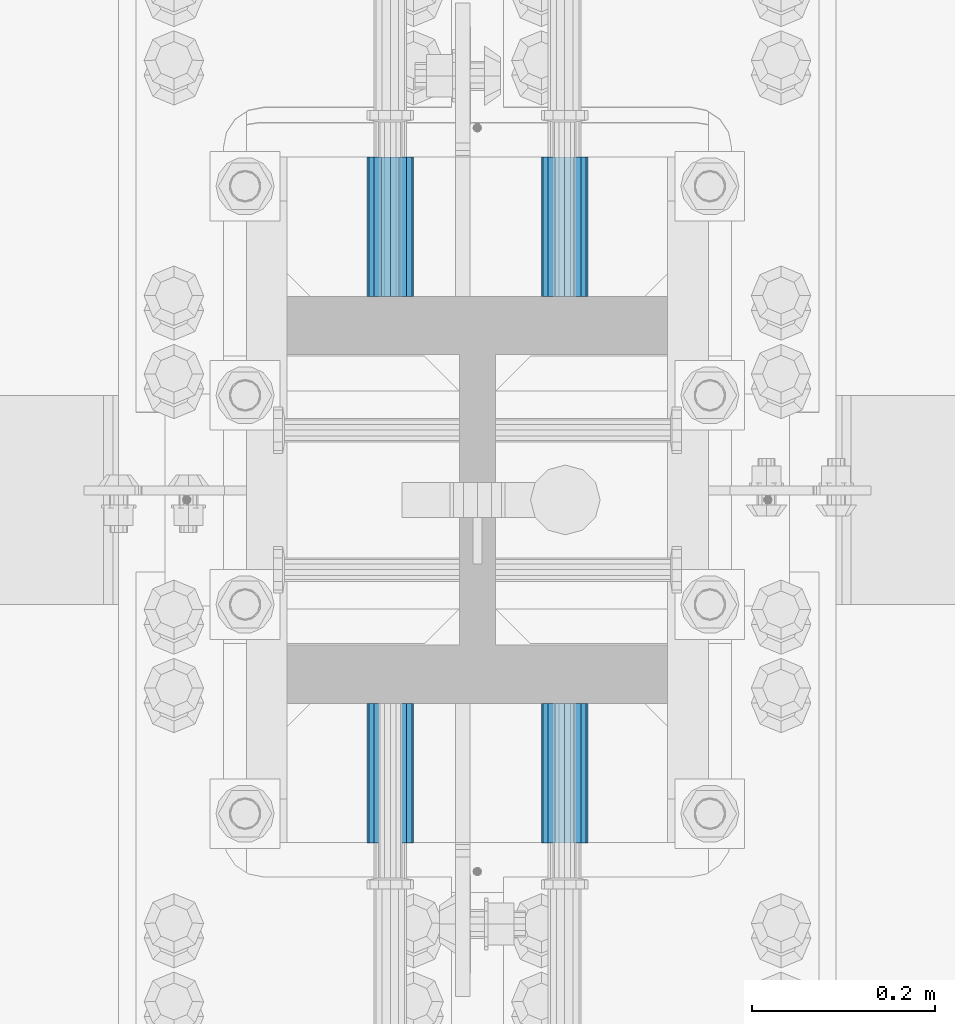
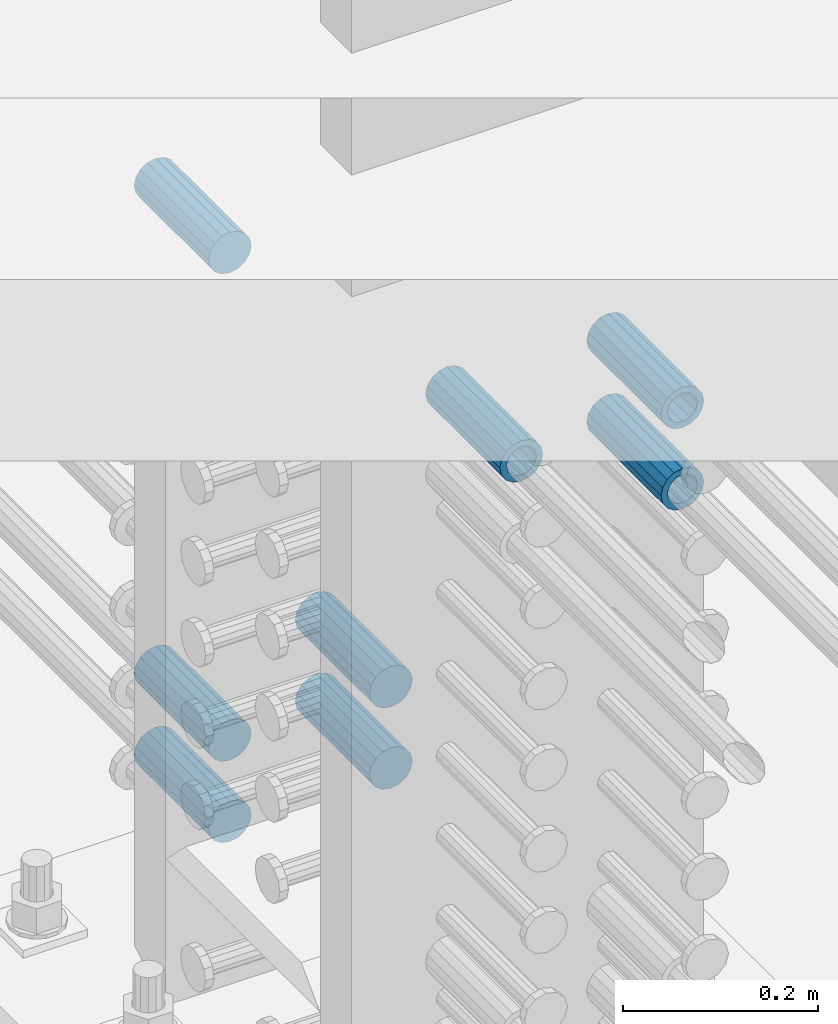
# One storey, part 1303 of 1763: 8 beams, 1 element without a shape of its own.
"""IFC2X3 building model written with IfcOpenShell, lengths in millimetres."""

from ifc_helpers import new_model, si_unit, frame, origin_with_axes, place, context, subcontext, project, spatial, faceted_brep, material, type_object, element, aggregate, save


model = new_model("IFC2X3")

# Units and contexts
model_context = context("Model", 3, precision=1e-05, world=origin_with_axes())
body_context = subcontext(model_context, "Body", "Model", "MODEL_VIEW")
ifc_project = project(units=[si_unit("LENGTHUNIT", "METRE", prefix="MILLI"), si_unit("AREAUNIT", "SQUARE_METRE"), si_unit("VOLUMEUNIT", "CUBIC_METRE"), si_unit("MASSUNIT", "GRAM", prefix="KILO"), si_unit("TIMEUNIT", "SECOND"), si_unit("PLANEANGLEUNIT", "RADIAN"), si_unit("SOLIDANGLEUNIT", "STERADIAN"), si_unit("THERMODYNAMICTEMPERATUREUNIT", "DEGREE_CELSIUS"), si_unit("LUMINOUSINTENSITYUNIT", "LUMEN")], contexts=[model_context])

# Site, building, storey
site_placement = place(None, origin_with_axes())
site = spatial("IfcSite", under=ifc_project, at=site_placement, CompositionType="ELEMENT")
building_placement = place(site_placement, origin_with_axes())
building = spatial("IfcBuilding", under=site, at=building_placement, Name="Undefined", CompositionType="ELEMENT")
storey_placement = place(building_placement, origin_with_axes())
storey = spatial("IfcBuildingStorey", under=building, at=storey_placement, Name="Undefined", CompositionType="ELEMENT", Elevation=0.0)

# Assembly, beams
assembly_placement = place(storey_placement, origin_with_axes())
assembly = element("IfcElementAssembly", 1, at=assembly_placement, inside=storey, Name="COLUMN", AssemblyPlace="NOTDEFINED", PredefinedType="RIGID_FRAME")
ifc_material = material(Name="STEEL/A706-GR.80")
beam_type = type_object("IfcBeamType", PredefinedType="NOTDEFINED")
beam_1_placement = place(assembly_placement, frame((-23932.5872736985, 234.764284790534, 4775.20000000009), z_axis=(0.0, 0.0, 1.0), x_axis=(0.0, -1.0, 0.0)))
beam_1 = element("IfcBeam", 2, at=beam_1_placement, type_object=beam_type, material=ifc_material, Name="HALF COUPLER F", context=body_context, shape_type="Brep", body=[
    faceted_brep([(32.7659999999996, -8.95349999999962, -15.507916905568), (32.7659999999996, 0.0, -17.9070000000002), (32.7659999999996, 8.95349999999962, -15.507916905568), (32.7659999999996, 15.507916905568, -8.95350000000008), (32.7659999999996, 17.9069999999992, 0.0), (32.7659999999996, 15.507916905568, 8.95350000000008), (32.7659999999996, 8.95349999999962, 15.507916905568), (32.7659999999996, 0.0, 17.9070000000002), (32.7659999999996, -8.95349999999962, 15.507916905568), (32.7659999999996, -15.507916905568, 8.95350000000008), (32.7659999999996, -17.9069999999992, 0.0), (32.7659999999996, -15.507916905568, -8.95350000000008), (152.400103102711, -15.507916905568, 8.95350000000008), (152.400103102711, -8.95349999999962, 15.507916905568), (152.400103102711, -17.9069999999992, 0.0), (152.400103102711, -15.507916905568, -8.95350000000008), (152.400103102711, -8.95349999999962, -15.507916905568), (152.400103102711, 0.0, -17.9070000000002), (152.400103102711, 8.95349999999962, -15.507916905568), (152.400103102711, 15.507916905568, -8.95350000000008), (152.400103102711, 17.9069999999992, 0.0), (152.400103102711, 15.507916905568, 8.95350000000008), (152.400103102711, 8.95349999999962, 15.507916905568), (152.400103102711, 0.0, 17.9070000000002), (0.0, -23.466540125788, 9.72015918207308), (0.0, -17.9605122421381, 17.9605122421385), (0.0, -9.72015918207398, 23.4665401257867), (0.0, 0.0, 25.4000000000001), (0.0, 9.72015918207398, 23.4665401257867), (0.0, 17.9605122421381, 17.9605122421385), (0.0, 23.466540125788, 9.72015918207308), (0.0, 25.4000000000015, 0.0), (0.0, 23.466540125788, -9.72015918207308), (0.0, 17.9605122421381, -17.9605122421385), (0.0, 9.72015918207398, -23.4665401257867), (0.0, 0.0, -25.4000000000001), (0.0, -9.72015918207398, -23.4665401257867), (0.0, -17.9605122421381, -17.9605122421385), (0.0, -23.466540125788, -9.72015918207308), (0.0, -25.4000000000015, 0.0), (152.400103102711, -25.4000000000015, 0.0), (152.400103102711, -23.466540125788, 9.72015918207308), (152.400103102711, -17.9605122421381, 17.9605122421385), (152.400103102711, -9.72015918207398, 23.4665401257867), (152.400103102711, 0.0, 25.4000000000001), (152.400103102711, 9.72015918207398, 23.4665401257867), (152.400103102711, 17.9605122421381, 17.9605122421385), (152.400103102711, 23.466540125788, 9.72015918207308), (152.400103102711, 25.4000000000015, 0.0), (152.400103102711, 23.466540125788, -9.72015918207308), (152.400103102711, 17.9605122421381, -17.9605122421385), (152.400103102711, 9.72015918207398, -23.4665401257867), (152.400103102711, 0.0, -25.4000000000001), (152.400103102711, -9.72015918207398, -23.4665401257867), (152.400103102711, -17.9605122421381, -17.9605122421385), (152.400103102711, -23.466540125788, -9.72015918207308)], [[[0, 1, 2, 3, 4, 5, 6, 7, 8, 9, 10, 11]], [[12, 9, 8, 13]], [[14, 10, 9, 12]], [[15, 11, 10, 14]], [[16, 0, 11, 15]], [[17, 1, 0, 16]], [[18, 2, 1, 17]], [[19, 3, 2, 18]], [[20, 4, 3, 19]], [[21, 5, 4, 20]], [[22, 6, 5, 21]], [[23, 7, 6, 22]], [[13, 8, 7, 23]], [[24, 25, 26, 27, 28, 29, 30, 31, 32, 33, 34, 35, 36, 37, 38, 39]], [[24, 39, 40, 41]], [[25, 24, 41, 42]], [[26, 25, 42, 43]], [[27, 26, 43, 44]], [[28, 27, 44, 45]], [[29, 28, 45, 46]], [[30, 29, 46, 47]], [[31, 30, 47, 48]], [[32, 31, 48, 49]], [[33, 32, 49, 50]], [[34, 33, 50, 51]], [[35, 34, 51, 52]], [[36, 35, 52, 53]], [[37, 36, 53, 54]], [[38, 37, 54, 55]], [[39, 38, 55, 40]], [[54, 53, 52, 51, 50, 49, 48, 47, 46, 45, 44, 43, 42, 41, 40, 55], [21, 20, 19, 18, 17, 16, 15, 14, 12, 13, 23, 22]]]),
])
beam_2_placement = place(assembly_placement, frame((-24123.0872736984, 234.764078583961, 4876.80000000009), z_axis=(0.0, 0.0, 1.0), x_axis=(0.0, -1.0, 0.0)))
beam_2 = element("IfcBeam", 3, at=beam_2_placement, type_object=beam_type, material=ifc_material, Name="HALF COUPLER F", context=body_context, shape_type="Brep", body=[
    faceted_brep([(32.7659999999996, -8.95349999999962, -15.507916905568), (32.7659999999996, 0.0, -17.9070000000002), (32.7659999999996, 8.95349999999962, -15.507916905568), (32.7659999999996, 15.507916905568, -8.95350000000008), (32.7659999999996, 17.9069999999992, 0.0), (32.7659999999996, 15.507916905568, 8.95350000000008), (32.7659999999996, 8.95349999999962, 15.507916905568), (32.7659999999996, 0.0, 17.9070000000002), (32.7659999999996, -8.95349999999962, 15.507916905568), (32.7659999999996, -15.507916905568, 8.95350000000008), (32.7659999999996, -17.9069999999992, 0.0), (32.7659999999996, -15.507916905568, -8.95350000000008), (152.400103102711, -15.507916905568, 8.95350000000008), (152.400103102711, -8.95349999999962, 15.507916905568), (152.400103102711, -17.9069999999992, 0.0), (152.400103102711, -15.507916905568, -8.95350000000008), (152.400103102711, -8.95349999999962, -15.507916905568), (152.400103102711, 0.0, -17.9070000000002), (152.400103102711, 8.95349999999962, -15.507916905568), (152.400103102711, 15.507916905568, -8.95350000000008), (152.400103102711, 17.9069999999992, 0.0), (152.400103102711, 15.507916905568, 8.95350000000008), (152.400103102711, 8.95349999999962, 15.507916905568), (152.400103102711, 0.0, 17.9070000000002), (0.0, -23.466540125788, 9.72015918207308), (0.0, -17.9605122421381, 17.9605122421385), (0.0, -9.72015918207398, 23.4665401257867), (0.0, 0.0, 25.4000000000001), (0.0, 9.72015918207398, 23.4665401257867), (0.0, 17.9605122421381, 17.9605122421385), (0.0, 23.466540125788, 9.72015918207308), (0.0, 25.4000000000015, 0.0), (0.0, 23.466540125788, -9.72015918207308), (0.0, 17.9605122421381, -17.9605122421385), (0.0, 9.72015918207398, -23.4665401257867), (0.0, 0.0, -25.4000000000001), (0.0, -9.72015918207398, -23.4665401257867), (0.0, -17.9605122421381, -17.9605122421385), (0.0, -23.466540125788, -9.72015918207308), (0.0, -25.4000000000015, 0.0), (152.400103102711, -25.4000000000015, 0.0), (152.400103102711, -23.466540125788, 9.72015918207308), (152.400103102711, -17.9605122421381, 17.9605122421385), (152.400103102711, -9.72015918207398, 23.4665401257867), (152.400103102711, 0.0, 25.4000000000001), (152.400103102711, 9.72015918207398, 23.4665401257867), (152.400103102711, 17.9605122421381, 17.9605122421385), (152.400103102711, 23.466540125788, 9.72015918207308), (152.400103102711, 25.4000000000015, 0.0), (152.400103102711, 23.466540125788, -9.72015918207308), (152.400103102711, 17.9605122421381, -17.9605122421385), (152.400103102711, 9.72015918207398, -23.4665401257867), (152.400103102711, 0.0, -25.4000000000001), (152.400103102711, -9.72015918207398, -23.4665401257867), (152.400103102711, -17.9605122421381, -17.9605122421385), (152.400103102711, -23.466540125788, -9.72015918207308)], [[[0, 1, 2, 3, 4, 5, 6, 7, 8, 9, 10, 11]], [[12, 9, 8, 13]], [[14, 10, 9, 12]], [[15, 11, 10, 14]], [[16, 0, 11, 15]], [[17, 1, 0, 16]], [[18, 2, 1, 17]], [[19, 3, 2, 18]], [[20, 4, 3, 19]], [[21, 5, 4, 20]], [[22, 6, 5, 21]], [[23, 7, 6, 22]], [[13, 8, 7, 23]], [[24, 25, 26, 27, 28, 29, 30, 31, 32, 33, 34, 35, 36, 37, 38, 39]], [[24, 39, 40, 41]], [[25, 24, 41, 42]], [[26, 25, 42, 43]], [[27, 26, 43, 44]], [[28, 27, 44, 45]], [[29, 28, 45, 46]], [[30, 29, 46, 47]], [[31, 30, 47, 48]], [[32, 31, 48, 49]], [[33, 32, 49, 50]], [[34, 33, 50, 51]], [[35, 34, 51, 52]], [[36, 35, 52, 53]], [[37, 36, 53, 54]], [[38, 37, 54, 55]], [[39, 38, 55, 40]], [[54, 53, 52, 51, 50, 49, 48, 47, 46, 45, 44, 43, 42, 41, 40, 55], [21, 20, 19, 18, 17, 16, 15, 14, 12, 13, 23, 22]]]),
])
beam_3_placement = place(assembly_placement, frame((-23932.5872736985, 234.764147319485, 4876.80000000009), z_axis=(0.0, 0.0, 1.0), x_axis=(0.0, -1.0, 0.0)))
beam_3 = element("IfcBeam", 4, at=beam_3_placement, type_object=beam_type, material=ifc_material, Name="HALF COUPLER F", context=body_context, shape_type="Brep", body=[
    faceted_brep([(32.7659999999996, -8.95349999999962, -15.507916905568), (32.7659999999996, 0.0, -17.9070000000002), (32.7659999999996, 8.95349999999962, -15.507916905568), (32.7659999999996, 15.507916905568, -8.95350000000008), (32.7659999999996, 17.9069999999992, 0.0), (32.7659999999996, 15.507916905568, 8.95350000000008), (32.7659999999996, 8.95349999999962, 15.507916905568), (32.7659999999996, 0.0, 17.9070000000002), (32.7659999999996, -8.95349999999962, 15.507916905568), (32.7659999999996, -15.507916905568, 8.95350000000008), (32.7659999999996, -17.9069999999992, 0.0), (32.7659999999996, -15.507916905568, -8.95350000000008), (152.400103102711, -15.507916905568, 8.95350000000008), (152.400103102711, -8.95349999999962, 15.507916905568), (152.400103102711, -17.9069999999992, 0.0), (152.400103102711, -15.507916905568, -8.95350000000008), (152.400103102711, -8.95349999999962, -15.507916905568), (152.400103102711, 0.0, -17.9070000000002), (152.400103102711, 8.95349999999962, -15.507916905568), (152.400103102711, 15.507916905568, -8.95350000000008), (152.400103102711, 17.9069999999992, 0.0), (152.400103102711, 15.507916905568, 8.95350000000008), (152.400103102711, 8.95349999999962, 15.507916905568), (152.400103102711, 0.0, 17.9070000000002), (0.0, -23.466540125788, 9.72015918207308), (0.0, -17.9605122421381, 17.9605122421385), (0.0, -9.72015918207398, 23.4665401257867), (0.0, 0.0, 25.4000000000001), (0.0, 9.72015918207398, 23.4665401257867), (0.0, 17.9605122421381, 17.9605122421385), (0.0, 23.466540125788, 9.72015918207308), (0.0, 25.4000000000015, 0.0), (0.0, 23.466540125788, -9.72015918207308), (0.0, 17.9605122421381, -17.9605122421385), (0.0, 9.72015918207398, -23.4665401257867), (0.0, 0.0, -25.4000000000001), (0.0, -9.72015918207398, -23.4665401257867), (0.0, -17.9605122421381, -17.9605122421385), (0.0, -23.466540125788, -9.72015918207308), (0.0, -25.4000000000015, 0.0), (152.400103102711, -25.4000000000015, 0.0), (152.400103102711, -23.466540125788, 9.72015918207308), (152.400103102711, -17.9605122421381, 17.9605122421385), (152.400103102711, -9.72015918207398, 23.4665401257867), (152.400103102711, 0.0, 25.4000000000001), (152.400103102711, 9.72015918207398, 23.4665401257867), (152.400103102711, 17.9605122421381, 17.9605122421385), (152.400103102711, 23.466540125788, 9.72015918207308), (152.400103102711, 25.4000000000015, 0.0), (152.400103102711, 23.466540125788, -9.72015918207308), (152.400103102711, 17.9605122421381, -17.9605122421385), (152.400103102711, 9.72015918207398, -23.4665401257867), (152.400103102711, 0.0, -25.4000000000001), (152.400103102711, -9.72015918207398, -23.4665401257867), (152.400103102711, -17.9605122421381, -17.9605122421385), (152.400103102711, -23.466540125788, -9.72015918207308)], [[[0, 1, 2, 3, 4, 5, 6, 7, 8, 9, 10, 11]], [[12, 9, 8, 13]], [[14, 10, 9, 12]], [[15, 11, 10, 14]], [[16, 0, 11, 15]], [[17, 1, 0, 16]], [[18, 2, 1, 17]], [[19, 3, 2, 18]], [[20, 4, 3, 19]], [[21, 5, 4, 20]], [[22, 6, 5, 21]], [[23, 7, 6, 22]], [[13, 8, 7, 23]], [[24, 25, 26, 27, 28, 29, 30, 31, 32, 33, 34, 35, 36, 37, 38, 39]], [[24, 39, 40, 41]], [[25, 24, 41, 42]], [[26, 25, 42, 43]], [[27, 26, 43, 44]], [[28, 27, 44, 45]], [[29, 28, 45, 46]], [[30, 29, 46, 47]], [[31, 30, 47, 48]], [[32, 31, 48, 49]], [[33, 32, 49, 50]], [[34, 33, 50, 51]], [[35, 34, 51, 52]], [[36, 35, 52, 53]], [[37, 36, 53, 54]], [[38, 37, 54, 55]], [[39, 38, 55, 40]], [[54, 53, 52, 51, 50, 49, 48, 47, 46, 45, 44, 43, 42, 41, 40, 55], [21, 20, 19, 18, 17, 16, 15, 14, 12, 13, 23, 22]]]),
])
beam_4_placement = place(assembly_placement, frame((-24123.0872736984, 679.449793794024, 4064.0), z_axis=(0.0, 0.0, 1.0), x_axis=(0.0, 1.0, 0.0)))
beam_4 = element("IfcBeam", 5, at=beam_4_placement, type_object=beam_type, material=ifc_material, Name="HALF COUPLER F", context=body_context, shape_type="Brep", body=[
    faceted_brep([(32.7659999999996, -8.95349999999962, -15.507916905568), (32.7659999999996, 0.0, -17.9070000000002), (32.7659999999996, 8.95349999999962, -15.507916905568), (32.7659999999996, 15.507916905568, -8.95350000000008), (32.7659999999996, 17.9069999999992, 0.0), (32.7659999999996, 15.507916905568, 8.95350000000008), (32.7659999999996, 8.95349999999962, 15.507916905568), (32.7659999999996, 0.0, 17.9070000000002), (32.7659999999996, -8.95349999999962, 15.507916905568), (32.7659999999996, -15.507916905568, 8.95350000000008), (32.7659999999996, -17.9069999999992, 0.0), (32.7659999999996, -15.507916905568, -8.95350000000008), (152.400103102711, -15.507916905568, 8.95350000000008), (152.400103102711, -8.95349999999962, 15.507916905568), (152.400103102711, -17.9069999999992, 0.0), (152.400103102711, -15.507916905568, -8.95350000000008), (152.400103102711, -8.95349999999962, -15.507916905568), (152.400103102711, 0.0, -17.9070000000002), (152.400103102711, 8.95349999999962, -15.507916905568), (152.400103102711, 15.507916905568, -8.95350000000008), (152.400103102711, 17.9069999999992, 0.0), (152.400103102711, 15.507916905568, 8.95350000000008), (152.400103102711, 8.95349999999962, 15.507916905568), (152.400103102711, 0.0, 17.9070000000002), (0.0, -23.466540125788, 9.72015918207308), (0.0, -17.9605122421381, 17.9605122421385), (0.0, -9.72015918207398, 23.4665401257867), (0.0, 0.0, 25.4000000000001), (0.0, 9.72015918207398, 23.4665401257867), (0.0, 17.9605122421381, 17.9605122421385), (0.0, 23.466540125788, 9.72015918207308), (0.0, 25.4000000000015, 0.0), (0.0, 23.466540125788, -9.72015918207308), (0.0, 17.9605122421381, -17.9605122421385), (0.0, 9.72015918207398, -23.4665401257867), (0.0, 0.0, -25.4000000000001), (0.0, -9.72015918207398, -23.4665401257867), (0.0, -17.9605122421381, -17.9605122421385), (0.0, -23.466540125788, -9.72015918207308), (0.0, -25.4000000000015, 0.0), (152.400103102711, -25.4000000000015, 0.0), (152.400103102711, -23.466540125788, 9.72015918207308), (152.400103102711, -17.9605122421381, 17.9605122421385), (152.400103102711, -9.72015918207398, 23.4665401257867), (152.400103102711, 0.0, 25.4000000000001), (152.400103102711, 9.72015918207398, 23.4665401257867), (152.400103102711, 17.9605122421381, 17.9605122421385), (152.400103102711, 23.466540125788, 9.72015918207308), (152.400103102711, 25.4000000000015, 0.0), (152.400103102711, 23.466540125788, -9.72015918207308), (152.400103102711, 17.9605122421381, -17.9605122421385), (152.400103102711, 9.72015918207398, -23.4665401257867), (152.400103102711, 0.0, -25.4000000000001), (152.400103102711, -9.72015918207398, -23.4665401257867), (152.400103102711, -17.9605122421381, -17.9605122421385), (152.400103102711, -23.466540125788, -9.72015918207308)], [[[0, 1, 2, 3, 4, 5, 6, 7, 8, 9, 10, 11]], [[12, 9, 8, 13]], [[14, 10, 9, 12]], [[15, 11, 10, 14]], [[16, 0, 11, 15]], [[17, 1, 0, 16]], [[18, 2, 1, 17]], [[19, 3, 2, 18]], [[20, 4, 3, 19]], [[21, 5, 4, 20]], [[22, 6, 5, 21]], [[23, 7, 6, 22]], [[13, 8, 7, 23]], [[24, 25, 26, 27, 28, 29, 30, 31, 32, 33, 34, 35, 36, 37, 38, 39]], [[24, 39, 40, 41]], [[25, 24, 41, 42]], [[26, 25, 42, 43]], [[27, 26, 43, 44]], [[28, 27, 44, 45]], [[29, 28, 45, 46]], [[30, 29, 46, 47]], [[31, 30, 47, 48]], [[32, 31, 48, 49]], [[33, 32, 49, 50]], [[34, 33, 50, 51]], [[35, 34, 51, 52]], [[36, 35, 52, 53]], [[37, 36, 53, 54]], [[38, 37, 54, 55]], [[39, 38, 55, 40]], [[54, 53, 52, 51, 50, 49, 48, 47, 46, 45, 44, 43, 42, 41, 40, 55], [21, 20, 19, 18, 17, 16, 15, 14, 12, 13, 23, 22]]]),
])
beam_5_placement = place(assembly_placement, frame((-23932.5872736985, 679.4497250585, 4064.0), z_axis=(0.0, 0.0, 1.0), x_axis=(0.0, 1.0, 0.0)))
beam_5 = element("IfcBeam", 6, at=beam_5_placement, type_object=beam_type, material=ifc_material, Name="HALF COUPLER F", context=body_context, shape_type="Brep", body=[
    faceted_brep([(32.7659999999996, -8.95349999999962, -15.507916905568), (32.7659999999996, 0.0, -17.9070000000002), (32.7659999999996, 8.95349999999962, -15.507916905568), (32.7659999999996, 15.507916905568, -8.95350000000008), (32.7659999999996, 17.9069999999992, 0.0), (32.7659999999996, 15.507916905568, 8.95350000000008), (32.7659999999996, 8.95349999999962, 15.507916905568), (32.7659999999996, 0.0, 17.9070000000002), (32.7659999999996, -8.95349999999962, 15.507916905568), (32.7659999999996, -15.507916905568, 8.95350000000008), (32.7659999999996, -17.9069999999992, 0.0), (32.7659999999996, -15.507916905568, -8.95350000000008), (152.400103102711, -15.507916905568, 8.95350000000008), (152.400103102711, -8.95349999999962, 15.507916905568), (152.400103102711, -17.9069999999992, 0.0), (152.400103102711, -15.507916905568, -8.95350000000008), (152.400103102711, -8.95349999999962, -15.507916905568), (152.400103102711, 0.0, -17.9070000000002), (152.400103102711, 8.95349999999962, -15.507916905568), (152.400103102711, 15.507916905568, -8.95350000000008), (152.400103102711, 17.9069999999992, 0.0), (152.400103102711, 15.507916905568, 8.95350000000008), (152.400103102711, 8.95349999999962, 15.507916905568), (152.400103102711, 0.0, 17.9070000000002), (0.0, -23.466540125788, 9.72015918207308), (0.0, -17.9605122421381, 17.9605122421385), (0.0, -9.72015918207398, 23.4665401257867), (0.0, 0.0, 25.4000000000001), (0.0, 9.72015918207398, 23.4665401257867), (0.0, 17.9605122421381, 17.9605122421385), (0.0, 23.466540125788, 9.72015918207308), (0.0, 25.4000000000015, 0.0), (0.0, 23.466540125788, -9.72015918207308), (0.0, 17.9605122421381, -17.9605122421385), (0.0, 9.72015918207398, -23.4665401257867), (0.0, 0.0, -25.4000000000001), (0.0, -9.72015918207398, -23.4665401257867), (0.0, -17.9605122421381, -17.9605122421385), (0.0, -23.466540125788, -9.72015918207308), (0.0, -25.4000000000015, 0.0), (152.400103102711, -25.4000000000015, 0.0), (152.400103102711, -23.466540125788, 9.72015918207308), (152.400103102711, -17.9605122421381, 17.9605122421385), (152.400103102711, -9.72015918207398, 23.4665401257867), (152.400103102711, 0.0, 25.4000000000001), (152.400103102711, 9.72015918207398, 23.4665401257867), (152.400103102711, 17.9605122421381, 17.9605122421385), (152.400103102711, 23.466540125788, 9.72015918207308), (152.400103102711, 25.4000000000015, 0.0), (152.400103102711, 23.466540125788, -9.72015918207308), (152.400103102711, 17.9605122421381, -17.9605122421385), (152.400103102711, 9.72015918207398, -23.4665401257867), (152.400103102711, 0.0, -25.4000000000001), (152.400103102711, -9.72015918207398, -23.4665401257867), (152.400103102711, -17.9605122421381, -17.9605122421385), (152.400103102711, -23.466540125788, -9.72015918207308)], [[[0, 1, 2, 3, 4, 5, 6, 7, 8, 9, 10, 11]], [[12, 9, 8, 13]], [[14, 10, 9, 12]], [[15, 11, 10, 14]], [[16, 0, 11, 15]], [[17, 1, 0, 16]], [[18, 2, 1, 17]], [[19, 3, 2, 18]], [[20, 4, 3, 19]], [[21, 5, 4, 20]], [[22, 6, 5, 21]], [[23, 7, 6, 22]], [[13, 8, 7, 23]], [[24, 25, 26, 27, 28, 29, 30, 31, 32, 33, 34, 35, 36, 37, 38, 39]], [[24, 39, 40, 41]], [[25, 24, 41, 42]], [[26, 25, 42, 43]], [[27, 26, 43, 44]], [[28, 27, 44, 45]], [[29, 28, 45, 46]], [[30, 29, 46, 47]], [[31, 30, 47, 48]], [[32, 31, 48, 49]], [[33, 32, 49, 50]], [[34, 33, 50, 51]], [[35, 34, 51, 52]], [[36, 35, 52, 53]], [[37, 36, 53, 54]], [[38, 37, 54, 55]], [[39, 38, 55, 40]], [[54, 53, 52, 51, 50, 49, 48, 47, 46, 45, 44, 43, 42, 41, 40, 55], [21, 20, 19, 18, 17, 16, 15, 14, 12, 13, 23, 22]]]),
])
beam_6_placement = place(assembly_placement, frame((-24123.0872736984, 679.449793794025, 4165.6), z_axis=(0.0, 0.0, 1.0), x_axis=(0.0, 1.0, 0.0)))
beam_6 = element("IfcBeam", 7, at=beam_6_placement, type_object=beam_type, material=ifc_material, Name="HALF COUPLER F", context=body_context, shape_type="Brep", body=[
    faceted_brep([(32.7659999999996, -8.95349999999962, -15.507916905568), (32.7659999999996, 0.0, -17.9070000000002), (32.7659999999996, 8.95349999999962, -15.507916905568), (32.7659999999996, 15.507916905568, -8.95350000000008), (32.7659999999996, 17.9069999999992, 0.0), (32.7659999999996, 15.507916905568, 8.95350000000008), (32.7659999999996, 8.95349999999962, 15.507916905568), (32.7659999999996, 0.0, 17.9070000000002), (32.7659999999996, -8.95349999999962, 15.507916905568), (32.7659999999996, -15.507916905568, 8.95350000000008), (32.7659999999996, -17.9069999999992, 0.0), (32.7659999999996, -15.507916905568, -8.95350000000008), (152.400103102711, -15.507916905568, 8.95350000000008), (152.400103102711, -8.95349999999962, 15.507916905568), (152.400103102711, -17.9069999999992, 0.0), (152.400103102711, -15.507916905568, -8.95350000000008), (152.400103102711, -8.95349999999962, -15.507916905568), (152.400103102711, 0.0, -17.9070000000002), (152.400103102711, 8.95349999999962, -15.507916905568), (152.400103102711, 15.507916905568, -8.95350000000008), (152.400103102711, 17.9069999999992, 0.0), (152.400103102711, 15.507916905568, 8.95350000000008), (152.400103102711, 8.95349999999962, 15.507916905568), (152.400103102711, 0.0, 17.9070000000002), (0.0, -23.466540125788, 9.72015918207308), (0.0, -17.9605122421381, 17.9605122421385), (0.0, -9.72015918207398, 23.4665401257867), (0.0, 0.0, 25.4000000000001), (0.0, 9.72015918207398, 23.4665401257867), (0.0, 17.9605122421381, 17.9605122421385), (0.0, 23.466540125788, 9.72015918207308), (0.0, 25.4000000000015, 0.0), (0.0, 23.466540125788, -9.72015918207308), (0.0, 17.9605122421381, -17.9605122421385), (0.0, 9.72015918207398, -23.4665401257867), (0.0, 0.0, -25.4000000000001), (0.0, -9.72015918207398, -23.4665401257867), (0.0, -17.9605122421381, -17.9605122421385), (0.0, -23.466540125788, -9.72015918207308), (0.0, -25.4000000000015, 0.0), (152.400103102711, -25.4000000000015, 0.0), (152.400103102711, -23.466540125788, 9.72015918207308), (152.400103102711, -17.9605122421381, 17.9605122421385), (152.400103102711, -9.72015918207398, 23.4665401257867), (152.400103102711, 0.0, 25.4000000000001), (152.400103102711, 9.72015918207398, 23.4665401257867), (152.400103102711, 17.9605122421381, 17.9605122421385), (152.400103102711, 23.466540125788, 9.72015918207308), (152.400103102711, 25.4000000000015, 0.0), (152.400103102711, 23.466540125788, -9.72015918207308), (152.400103102711, 17.9605122421381, -17.9605122421385), (152.400103102711, 9.72015918207398, -23.4665401257867), (152.400103102711, 0.0, -25.4000000000001), (152.400103102711, -9.72015918207398, -23.4665401257867), (152.400103102711, -17.9605122421381, -17.9605122421385), (152.400103102711, -23.466540125788, -9.72015918207308)], [[[0, 1, 2, 3, 4, 5, 6, 7, 8, 9, 10, 11]], [[12, 9, 8, 13]], [[14, 10, 9, 12]], [[15, 11, 10, 14]], [[16, 0, 11, 15]], [[17, 1, 0, 16]], [[18, 2, 1, 17]], [[19, 3, 2, 18]], [[20, 4, 3, 19]], [[21, 5, 4, 20]], [[22, 6, 5, 21]], [[23, 7, 6, 22]], [[13, 8, 7, 23]], [[24, 25, 26, 27, 28, 29, 30, 31, 32, 33, 34, 35, 36, 37, 38, 39]], [[24, 39, 40, 41]], [[25, 24, 41, 42]], [[26, 25, 42, 43]], [[27, 26, 43, 44]], [[28, 27, 44, 45]], [[29, 28, 45, 46]], [[30, 29, 46, 47]], [[31, 30, 47, 48]], [[32, 31, 48, 49]], [[33, 32, 49, 50]], [[34, 33, 50, 51]], [[35, 34, 51, 52]], [[36, 35, 52, 53]], [[37, 36, 53, 54]], [[38, 37, 54, 55]], [[39, 38, 55, 40]], [[54, 53, 52, 51, 50, 49, 48, 47, 46, 45, 44, 43, 42, 41, 40, 55], [21, 20, 19, 18, 17, 16, 15, 14, 12, 13, 23, 22]]]),
])
beam_7_placement = place(assembly_placement, frame((-23932.5872736985, 679.449725058501, 4165.6), z_axis=(0.0, 0.0, 1.0), x_axis=(0.0, 1.0, 0.0)))
beam_7 = element("IfcBeam", 8, at=beam_7_placement, type_object=beam_type, material=ifc_material, Name="HALF COUPLER F", context=body_context, shape_type="Brep", body=[
    faceted_brep([(32.7659999999996, -8.95349999999962, -15.507916905568), (32.7659999999996, 0.0, -17.9070000000002), (32.7659999999996, 8.95349999999962, -15.507916905568), (32.7659999999996, 15.507916905568, -8.95350000000008), (32.7659999999996, 17.9069999999992, 0.0), (32.7659999999996, 15.507916905568, 8.95350000000008), (32.7659999999996, 8.95349999999962, 15.507916905568), (32.7659999999996, 0.0, 17.9070000000002), (32.7659999999996, -8.95349999999962, 15.507916905568), (32.7659999999996, -15.507916905568, 8.95350000000008), (32.7659999999996, -17.9069999999992, 0.0), (32.7659999999996, -15.507916905568, -8.95350000000008), (152.400103102711, -15.507916905568, 8.95350000000008), (152.400103102711, -8.95349999999962, 15.507916905568), (152.400103102711, -17.9069999999992, 0.0), (152.400103102711, -15.507916905568, -8.95350000000008), (152.400103102711, -8.95349999999962, -15.507916905568), (152.400103102711, 0.0, -17.9070000000002), (152.400103102711, 8.95349999999962, -15.507916905568), (152.400103102711, 15.507916905568, -8.95350000000008), (152.400103102711, 17.9069999999992, 0.0), (152.400103102711, 15.507916905568, 8.95350000000008), (152.400103102711, 8.95349999999962, 15.507916905568), (152.400103102711, 0.0, 17.9070000000002), (0.0, -23.466540125788, 9.72015918207308), (0.0, -17.9605122421381, 17.9605122421385), (0.0, -9.72015918207398, 23.4665401257867), (0.0, 0.0, 25.4000000000001), (0.0, 9.72015918207398, 23.4665401257867), (0.0, 17.9605122421381, 17.9605122421385), (0.0, 23.466540125788, 9.72015918207308), (0.0, 25.4000000000015, 0.0), (0.0, 23.466540125788, -9.72015918207308), (0.0, 17.9605122421381, -17.9605122421385), (0.0, 9.72015918207398, -23.4665401257867), (0.0, 0.0, -25.4000000000001), (0.0, -9.72015918207398, -23.4665401257867), (0.0, -17.9605122421381, -17.9605122421385), (0.0, -23.466540125788, -9.72015918207308), (0.0, -25.4000000000015, 0.0), (152.400103102711, -25.4000000000015, 0.0), (152.400103102711, -23.466540125788, 9.72015918207308), (152.400103102711, -17.9605122421381, 17.9605122421385), (152.400103102711, -9.72015918207398, 23.4665401257867), (152.400103102711, 0.0, 25.4000000000001), (152.400103102711, 9.72015918207398, 23.4665401257867), (152.400103102711, 17.9605122421381, 17.9605122421385), (152.400103102711, 23.466540125788, 9.72015918207308), (152.400103102711, 25.4000000000015, 0.0), (152.400103102711, 23.466540125788, -9.72015918207308), (152.400103102711, 17.9605122421381, -17.9605122421385), (152.400103102711, 9.72015918207398, -23.4665401257867), (152.400103102711, 0.0, -25.4000000000001), (152.400103102711, -9.72015918207398, -23.4665401257867), (152.400103102711, -17.9605122421381, -17.9605122421385), (152.400103102711, -23.466540125788, -9.72015918207308)], [[[0, 1, 2, 3, 4, 5, 6, 7, 8, 9, 10, 11]], [[12, 9, 8, 13]], [[14, 10, 9, 12]], [[15, 11, 10, 14]], [[16, 0, 11, 15]], [[17, 1, 0, 16]], [[18, 2, 1, 17]], [[19, 3, 2, 18]], [[20, 4, 3, 19]], [[21, 5, 4, 20]], [[22, 6, 5, 21]], [[23, 7, 6, 22]], [[13, 8, 7, 23]], [[24, 25, 26, 27, 28, 29, 30, 31, 32, 33, 34, 35, 36, 37, 38, 39]], [[24, 39, 40, 41]], [[25, 24, 41, 42]], [[26, 25, 42, 43]], [[27, 26, 43, 44]], [[28, 27, 44, 45]], [[29, 28, 45, 46]], [[30, 29, 46, 47]], [[31, 30, 47, 48]], [[32, 31, 48, 49]], [[33, 32, 49, 50]], [[34, 33, 50, 51]], [[35, 34, 51, 52]], [[36, 35, 52, 53]], [[37, 36, 53, 54]], [[38, 37, 54, 55]], [[39, 38, 55, 40]], [[54, 53, 52, 51, 50, 49, 48, 47, 46, 45, 44, 43, 42, 41, 40, 55], [21, 20, 19, 18, 17, 16, 15, 14, 12, 13, 23, 22]]]),
])
beam_8_placement = place(assembly_placement, frame((-24123.0872736984, 679.449931264473, 4775.20000000009), z_axis=(0.0, 0.0, 1.0), x_axis=(0.0, 1.0, 0.0)))
beam_8 = element("IfcBeam", 9, at=beam_8_placement, type_object=beam_type, material=ifc_material, Name="HALF COUPLER F", context=body_context, shape_type="Brep", body=[
    faceted_brep([(32.7659999999996, -8.95349999999962, -15.507916905568), (32.7659999999996, 0.0, -17.9070000000002), (32.7659999999996, 8.95349999999962, -15.507916905568), (32.7659999999996, 15.507916905568, -8.95350000000008), (32.7659999999996, 17.9069999999992, 0.0), (32.7659999999996, 15.507916905568, 8.95350000000008), (32.7659999999996, 8.95349999999962, 15.507916905568), (32.7659999999996, 0.0, 17.9070000000002), (32.7659999999996, -8.95349999999962, 15.507916905568), (32.7659999999996, -15.507916905568, 8.95350000000008), (32.7659999999996, -17.9069999999992, 0.0), (32.7659999999996, -15.507916905568, -8.95350000000008), (152.400103102711, -15.507916905568, 8.95350000000008), (152.400103102711, -8.95349999999962, 15.507916905568), (152.400103102711, -17.9069999999992, 0.0), (152.400103102711, -15.507916905568, -8.95350000000008), (152.400103102711, -8.95349999999962, -15.507916905568), (152.400103102711, 0.0, -17.9070000000002), (152.400103102711, 8.95349999999962, -15.507916905568), (152.400103102711, 15.507916905568, -8.95350000000008), (152.400103102711, 17.9069999999992, 0.0), (152.400103102711, 15.507916905568, 8.95350000000008), (152.400103102711, 8.95349999999962, 15.507916905568), (152.400103102711, 0.0, 17.9070000000002), (0.0, -23.466540125788, 9.72015918207308), (0.0, -17.9605122421381, 17.9605122421385), (0.0, -9.72015918207398, 23.4665401257867), (0.0, 0.0, 25.4000000000001), (0.0, 9.72015918207398, 23.4665401257867), (0.0, 17.9605122421381, 17.9605122421385), (0.0, 23.466540125788, 9.72015918207308), (0.0, 25.4000000000015, 0.0), (0.0, 23.466540125788, -9.72015918207308), (0.0, 17.9605122421381, -17.9605122421385), (0.0, 9.72015918207398, -23.4665401257867), (0.0, 0.0, -25.4000000000001), (0.0, -9.72015918207398, -23.4665401257867), (0.0, -17.9605122421381, -17.9605122421385), (0.0, -23.466540125788, -9.72015918207308), (0.0, -25.4000000000015, 0.0), (152.400103102711, -25.4000000000015, 0.0), (152.400103102711, -23.466540125788, 9.72015918207308), (152.400103102711, -17.9605122421381, 17.9605122421385), (152.400103102711, -9.72015918207398, 23.4665401257867), (152.400103102711, 0.0, 25.4000000000001), (152.400103102711, 9.72015918207398, 23.4665401257867), (152.400103102711, 17.9605122421381, 17.9605122421385), (152.400103102711, 23.466540125788, 9.72015918207308), (152.400103102711, 25.4000000000015, 0.0), (152.400103102711, 23.466540125788, -9.72015918207308), (152.400103102711, 17.9605122421381, -17.9605122421385), (152.400103102711, 9.72015918207398, -23.4665401257867), (152.400103102711, 0.0, -25.4000000000001), (152.400103102711, -9.72015918207398, -23.4665401257867), (152.400103102711, -17.9605122421381, -17.9605122421385), (152.400103102711, -23.466540125788, -9.72015918207308)], [[[0, 1, 2, 3, 4, 5, 6, 7, 8, 9, 10, 11]], [[12, 9, 8, 13]], [[14, 10, 9, 12]], [[15, 11, 10, 14]], [[16, 0, 11, 15]], [[17, 1, 0, 16]], [[18, 2, 1, 17]], [[19, 3, 2, 18]], [[20, 4, 3, 19]], [[21, 5, 4, 20]], [[22, 6, 5, 21]], [[23, 7, 6, 22]], [[13, 8, 7, 23]], [[24, 25, 26, 27, 28, 29, 30, 31, 32, 33, 34, 35, 36, 37, 38, 39]], [[24, 39, 40, 41]], [[25, 24, 41, 42]], [[26, 25, 42, 43]], [[27, 26, 43, 44]], [[28, 27, 44, 45]], [[29, 28, 45, 46]], [[30, 29, 46, 47]], [[31, 30, 47, 48]], [[32, 31, 48, 49]], [[33, 32, 49, 50]], [[34, 33, 50, 51]], [[35, 34, 51, 52]], [[36, 35, 52, 53]], [[37, 36, 53, 54]], [[38, 37, 54, 55]], [[39, 38, 55, 40]], [[54, 53, 52, 51, 50, 49, 48, 47, 46, 45, 44, 43, 42, 41, 40, 55], [21, 20, 19, 18, 17, 16, 15, 14, 12, 13, 23, 22]]]),
])
aggregate(assembly, [beam_1, beam_2, beam_3, beam_4, beam_5, beam_6, beam_7, beam_8])

save(model, "model.ifc")
